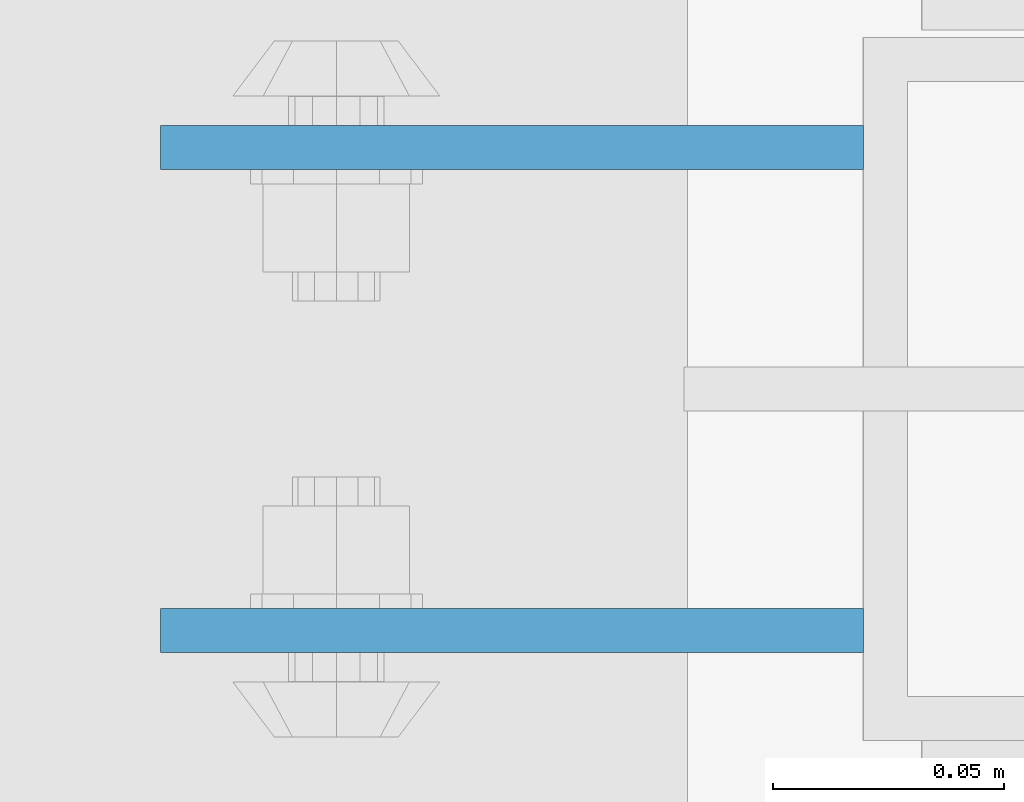
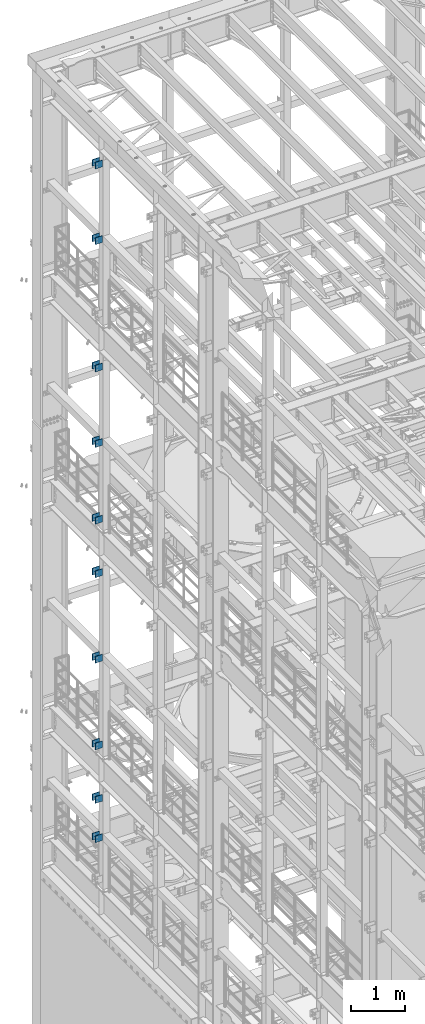
# One storey, part 1308 of 1876: 20 beams, 4 elements without a shape of their own.
"""IFC2X3 building model written with IfcOpenShell, lengths in millimetres."""

from ifc_helpers import new_model, si_unit, frame, origin_with_axes, place, context, subcontext, project, spatial, faceted_brep, material, type_object, element, aggregate, save


model = new_model("IFC2X3")

# Units and contexts
model_context = context("Model", 3, precision=1e-05, world=origin_with_axes())
body_context = subcontext(model_context, "Body", "Model", "MODEL_VIEW")
ifc_project = project(units=[si_unit("LENGTHUNIT", "METRE", prefix="MILLI"), si_unit("AREAUNIT", "SQUARE_METRE"), si_unit("VOLUMEUNIT", "CUBIC_METRE"), si_unit("MASSUNIT", "GRAM", prefix="KILO"), si_unit("TIMEUNIT", "SECOND"), si_unit("PLANEANGLEUNIT", "RADIAN"), si_unit("SOLIDANGLEUNIT", "STERADIAN"), si_unit("THERMODYNAMICTEMPERATUREUNIT", "DEGREE_CELSIUS"), si_unit("LUMINOUSINTENSITYUNIT", "LUMEN")], contexts=[model_context])

# Site, building, storey
site_placement = place(None, origin_with_axes())
site = spatial("IfcSite", under=ifc_project, at=site_placement, CompositionType="ELEMENT")
building_placement = place(site_placement, origin_with_axes())
building = spatial("IfcBuilding", under=site, at=building_placement, Name="Undefined", CompositionType="ELEMENT")
storey_placement = place(building_placement, origin_with_axes())
storey = spatial("IfcBuildingStorey", under=building, at=storey_placement, Name="Undefined", CompositionType="ELEMENT", Elevation=0.0)

# Assembly, beams
assembly_1_placement = place(storey_placement, origin_with_axes())
assembly_1 = element("IfcElementAssembly", 1, at=assembly_1_placement, inside=storey, Name="BEAM", AssemblyPlace="NOTDEFINED", PredefinedType="RIGID_FRAME")
ifc_material = material(Name="STEEL/A36")
beam_type = type_object("IfcBeamType", PredefinedType="NOTDEFINED")
beam_1_placement = place(assembly_1_placement, frame((-76.2000002548895, 11736.3875, 21678.9), z_axis=(0.0, 0.0, -1.0), x_axis=(-1.0, 0.0, 0.0)))
beam_1 = element("IfcBeam", 2, at=beam_1_placement, type_object=beam_type, material=ifc_material, Name="PLATE", context=body_context, shape_type="Brep", body=[
    faceted_brep([(0.0, 4.76249999999982, -76.1999999999998), (3.63797880709171e-12, 4.76249999999982, 76.1999969482422), (152.399993896484, 4.76250000000073, 76.1999969482422), (152.4, 4.76249999999982, -76.1999999999998), (3.63797880709171e-12, -4.76249999999982, 76.1999969482422), (152.399993896484, -4.76250000000073, 76.1999969482422), (0.0, -4.76249999999982, -76.1999999999998), (152.4, -4.76249999999982, -76.1999999999998)], [[[0, 1, 2, 3]], [[4, 5, 2, 1]], [[4, 6, 7, 5]], [[6, 0, 3, 7]], [[5, 7, 3, 2]], [[6, 4, 1, 0]]]),
])
beam_2_placement = place(assembly_1_placement, frame((-76.2000002548895, 11631.6125, 21678.9), z_axis=(0.0, 0.0, -1.0), x_axis=(-1.0, 0.0, 0.0)))
beam_2 = element("IfcBeam", 3, at=beam_2_placement, type_object=beam_type, material=ifc_material, Name="PLATE", context=body_context, shape_type="Brep", body=[
    faceted_brep([(0.0, 4.76249999999982, -76.1999999999998), (3.63797880709171e-12, 4.76249999999982, 76.1999969482422), (152.399993896484, 4.76250000000073, 76.1999969482422), (152.4, 4.76249999999982, -76.1999999999998), (3.63797880709171e-12, -4.76249999999982, 76.1999969482422), (152.399993896484, -4.76250000000073, 76.1999969482422), (0.0, -4.76249999999982, -76.1999999999998), (152.4, -4.76249999999982, -76.1999999999998)], [[[0, 1, 2, 3]], [[4, 5, 2, 1]], [[4, 6, 7, 5]], [[6, 0, 3, 7]], [[5, 7, 3, 2]], [[6, 4, 1, 0]]]),
])
beam_3_placement = place(assembly_1_placement, frame((-76.2000002548895, 11736.3875, 19958.05), z_axis=(0.0, 0.0, -1.0), x_axis=(-1.0, 0.0, 0.0)))
beam_3 = element("IfcBeam", 4, at=beam_3_placement, type_object=beam_type, material=ifc_material, Name="PLATE", context=body_context, shape_type="Brep", body=[
    faceted_brep([(0.0, 4.76249999999982, -76.1999999999998), (3.63797880709171e-12, 4.76249999999982, 76.1999969482422), (152.399993896484, 4.76250000000073, 76.1999969482422), (152.4, 4.76249999999982, -76.1999999999998), (3.63797880709171e-12, -4.76249999999982, 76.1999969482422), (152.399993896484, -4.76250000000073, 76.1999969482422), (0.0, -4.76249999999982, -76.1999999999998), (152.4, -4.76249999999982, -76.1999999999998)], [[[0, 1, 2, 3]], [[4, 5, 2, 1]], [[4, 6, 7, 5]], [[6, 0, 3, 7]], [[5, 7, 3, 2]], [[6, 4, 1, 0]]]),
])
beam_4_placement = place(assembly_1_placement, frame((-76.2000002548895, 11631.6125, 19958.05), z_axis=(0.0, 0.0, -1.0), x_axis=(-1.0, 0.0, 0.0)))
beam_4 = element("IfcBeam", 5, at=beam_4_placement, type_object=beam_type, material=ifc_material, Name="PLATE", context=body_context, shape_type="Brep", body=[
    faceted_brep([(0.0, 4.76249999999982, -76.1999999999998), (3.63797880709171e-12, 4.76249999999982, 76.1999969482422), (152.399993896484, 4.76250000000073, 76.1999969482422), (152.4, 4.76249999999982, -76.1999999999998), (3.63797880709171e-12, -4.76249999999982, 76.1999969482422), (152.399993896484, -4.76250000000073, 76.1999969482422), (0.0, -4.76249999999982, -76.1999999999998), (152.4, -4.76249999999982, -76.1999999999998)], [[[0, 1, 2, 3]], [[4, 5, 2, 1]], [[4, 6, 7, 5]], [[6, 0, 3, 7]], [[5, 7, 3, 2]], [[6, 4, 1, 0]]]),
])
aggregate(assembly_1, [beam_1, beam_2, beam_3, beam_4])

assembly_2_placement = place(storey_placement, origin_with_axes())
assembly_2 = element("IfcElementAssembly", 6, at=assembly_2_placement, inside=storey, Name="BEAM", AssemblyPlace="NOTDEFINED", PredefinedType="RIGID_FRAME")
beam_5_placement = place(assembly_2_placement, frame((-76.1999999999999, 11736.3875, 13589.0), z_axis=(0.0, 0.0, -1.0), x_axis=(-1.0, 0.0, 0.0)))
beam_5 = element("IfcBeam", 7, at=beam_5_placement, type_object=beam_type, material=ifc_material, Name="PLATE", context=body_context, shape_type="Brep", body=[
    faceted_brep([(0.0, 4.76249999999982, -76.1999999999998), (3.63797880709171e-12, 4.76249999999982, 76.1999969482422), (152.399993896484, 4.76250000000073, 76.1999969482422), (152.4, 4.76249999999982, -76.1999999999998), (3.63797880709171e-12, -4.76249999999982, 76.1999969482422), (152.399993896484, -4.76250000000073, 76.1999969482422), (0.0, -4.76249999999982, -76.1999999999998), (152.4, -4.76249999999982, -76.1999999999998)], [[[0, 1, 2, 3]], [[4, 5, 2, 1]], [[4, 6, 7, 5]], [[6, 0, 3, 7]], [[5, 7, 3, 2]], [[6, 4, 1, 0]]]),
])
beam_6_placement = place(assembly_2_placement, frame((-76.1999999999999, 11631.6125, 13589.0), z_axis=(0.0, 0.0, -1.0), x_axis=(-1.0, 0.0, 0.0)))
beam_6 = element("IfcBeam", 8, at=beam_6_placement, type_object=beam_type, material=ifc_material, Name="PLATE", context=body_context, shape_type="Brep", body=[
    faceted_brep([(0.0, 4.76249999999982, -76.1999999999998), (3.63797880709171e-12, 4.76249999999982, 76.1999969482422), (152.399993896484, 4.76250000000073, 76.1999969482422), (152.4, 4.76249999999982, -76.1999999999998), (3.63797880709171e-12, -4.76249999999982, 76.1999969482422), (152.399993896484, -4.76250000000073, 76.1999969482422), (0.0, -4.76249999999982, -76.1999999999998), (152.4, -4.76249999999982, -76.1999999999998)], [[[0, 1, 2, 3]], [[4, 5, 2, 1]], [[4, 6, 7, 5]], [[6, 0, 3, 7]], [[5, 7, 3, 2]], [[6, 4, 1, 0]]]),
])
beam_7_placement = place(assembly_2_placement, frame((-76.2, 11736.3875, 17056.1), z_axis=(0.0, 0.0, -1.0), x_axis=(-1.0, 0.0, 0.0)))
beam_7 = element("IfcBeam", 9, at=beam_7_placement, type_object=beam_type, material=ifc_material, Name="PLATE", context=body_context, shape_type="Brep", body=[
    faceted_brep([(0.0, 4.76249999999982, -76.1999999999998), (3.63797880709171e-12, 4.76249999999982, 76.1999969482422), (152.399993896484, 4.76250000000073, 76.1999969482422), (152.4, 4.76249999999982, -76.1999999999998), (3.63797880709171e-12, -4.76249999999982, 76.1999969482422), (152.399993896484, -4.76250000000073, 76.1999969482422), (0.0, -4.76249999999982, -76.1999999999998), (152.4, -4.76249999999982, -76.1999999999998)], [[[0, 1, 2, 3]], [[4, 5, 2, 1]], [[4, 6, 7, 5]], [[6, 0, 3, 7]], [[5, 7, 3, 2]], [[6, 4, 1, 0]]]),
])
beam_8_placement = place(assembly_2_placement, frame((-76.2, 11631.6125, 17056.1), z_axis=(0.0, 0.0, -1.0), x_axis=(-1.0, 0.0, 0.0)))
beam_8 = element("IfcBeam", 10, at=beam_8_placement, type_object=beam_type, material=ifc_material, Name="PLATE", context=body_context, shape_type="Brep", body=[
    faceted_brep([(0.0, 4.76249999999982, -76.1999999999998), (3.63797880709171e-12, 4.76249999999982, 76.1999969482422), (152.399993896484, 4.76250000000073, 76.1999969482422), (152.4, 4.76249999999982, -76.1999999999998), (3.63797880709171e-12, -4.76249999999982, 76.1999969482422), (152.399993896484, -4.76250000000073, 76.1999969482422), (0.0, -4.76249999999982, -76.1999999999998), (152.4, -4.76249999999982, -76.1999999999998)], [[[0, 1, 2, 3]], [[4, 5, 2, 1]], [[4, 6, 7, 5]], [[6, 0, 3, 7]], [[5, 7, 3, 2]], [[6, 4, 1, 0]]]),
])
beam_9_placement = place(assembly_2_placement, frame((-76.2, 11736.3875, 15335.25), z_axis=(0.0, 0.0, -1.0), x_axis=(-1.0, 0.0, 0.0)))
beam_9 = element("IfcBeam", 11, at=beam_9_placement, type_object=beam_type, material=ifc_material, Name="PLATE", context=body_context, shape_type="Brep", body=[
    faceted_brep([(0.0, 4.76249999999982, -76.1999999999998), (3.63797880709171e-12, 4.76249999999982, 76.1999969482422), (152.399993896484, 4.76250000000073, 76.1999969482422), (152.4, 4.76249999999982, -76.1999999999998), (3.63797880709171e-12, -4.76249999999982, 76.1999969482422), (152.399993896484, -4.76250000000073, 76.1999969482422), (0.0, -4.76249999999982, -76.1999999999998), (152.4, -4.76249999999982, -76.1999999999998)], [[[0, 1, 2, 3]], [[4, 5, 2, 1]], [[4, 6, 7, 5]], [[6, 0, 3, 7]], [[5, 7, 3, 2]], [[6, 4, 1, 0]]]),
])
beam_10_placement = place(assembly_2_placement, frame((-76.2, 11631.6125, 15335.25), z_axis=(0.0, 0.0, -1.0), x_axis=(-1.0, 0.0, 0.0)))
beam_10 = element("IfcBeam", 12, at=beam_10_placement, type_object=beam_type, material=ifc_material, Name="PLATE", context=body_context, shape_type="Brep", body=[
    faceted_brep([(0.0, 4.76249999999982, -76.1999999999998), (3.63797880709171e-12, 4.76249999999982, 76.1999969482422), (152.399993896484, 4.76250000000073, 76.1999969482422), (152.4, 4.76249999999982, -76.1999999999998), (3.63797880709171e-12, -4.76249999999982, 76.1999969482422), (152.399993896484, -4.76250000000073, 76.1999969482422), (0.0, -4.76249999999982, -76.1999999999998), (152.4, -4.76249999999982, -76.1999999999998)], [[[0, 1, 2, 3]], [[4, 5, 2, 1]], [[4, 6, 7, 5]], [[6, 0, 3, 7]], [[5, 7, 3, 2]], [[6, 4, 1, 0]]]),
])
aggregate(assembly_2, [beam_5, beam_6, beam_7, beam_8, beam_9, beam_10])

assembly_3_placement = place(storey_placement, origin_with_axes())
assembly_3 = element("IfcElementAssembly", 13, at=assembly_3_placement, inside=storey, Name="BEAM", AssemblyPlace="NOTDEFINED", PredefinedType="RIGID_FRAME")
beam_11_placement = place(assembly_3_placement, frame((-76.1999999999999, 11736.3875, 12369.8), z_axis=(0.0, 0.0, -1.0), x_axis=(-1.0, 0.0, 0.0)))
beam_11 = element("IfcBeam", 14, at=beam_11_placement, type_object=beam_type, material=ifc_material, Name="PLATE", context=body_context, shape_type="Brep", body=[
    faceted_brep([(0.0, 4.76249999999982, -76.1999999999998), (3.63797880709171e-12, 4.76249999999982, 76.1999969482422), (152.399993896484, 4.76250000000073, 76.1999969482422), (152.4, 4.76249999999982, -76.1999999999998), (3.63797880709171e-12, -4.76249999999982, 76.1999969482422), (152.399993896484, -4.76250000000073, 76.1999969482422), (0.0, -4.76249999999982, -76.1999999999998), (152.4, -4.76249999999982, -76.1999999999998)], [[[0, 1, 2, 3]], [[4, 5, 2, 1]], [[4, 6, 7, 5]], [[6, 0, 3, 7]], [[5, 7, 3, 2]], [[6, 4, 1, 0]]]),
])
beam_12_placement = place(assembly_3_placement, frame((-76.1999999999999, 11631.6125, 12369.8), z_axis=(0.0, 0.0, -1.0), x_axis=(-1.0, 0.0, 0.0)))
beam_12 = element("IfcBeam", 15, at=beam_12_placement, type_object=beam_type, material=ifc_material, Name="PLATE", context=body_context, shape_type="Brep", body=[
    faceted_brep([(0.0, 4.76249999999982, -76.1999999999998), (3.63797880709171e-12, 4.76249999999982, 76.1999969482422), (152.399993896484, 4.76250000000073, 76.1999969482422), (152.4, 4.76249999999982, -76.1999999999998), (3.63797880709171e-12, -4.76249999999982, 76.1999969482422), (152.399993896484, -4.76250000000073, 76.1999969482422), (0.0, -4.76249999999982, -76.1999999999998), (152.4, -4.76249999999982, -76.1999999999998)], [[[0, 1, 2, 3]], [[4, 5, 2, 1]], [[4, 6, 7, 5]], [[6, 0, 3, 7]], [[5, 7, 3, 2]], [[6, 4, 1, 0]]]),
])
beam_13_placement = place(assembly_3_placement, frame((-76.2, 11736.3875, 8445.5), z_axis=(0.0, 0.0, -1.0), x_axis=(-1.0, 0.0, 0.0)))
beam_13 = element("IfcBeam", 16, at=beam_13_placement, type_object=beam_type, material=ifc_material, Name="PLATE", context=body_context, shape_type="Brep", body=[
    faceted_brep([(0.0, 4.76249999999982, -76.1999999999998), (3.63797880709171e-12, 4.76249999999982, 76.1999969482422), (152.399993896484, 4.76250000000073, 76.1999969482422), (152.4, 4.76249999999982, -76.1999999999998), (3.63797880709171e-12, -4.76249999999982, 76.1999969482422), (152.399993896484, -4.76250000000073, 76.1999969482422), (0.0, -4.76249999999982, -76.1999999999998), (152.4, -4.76249999999982, -76.1999999999998)], [[[0, 1, 2, 3]], [[4, 5, 2, 1]], [[4, 6, 7, 5]], [[6, 0, 3, 7]], [[5, 7, 3, 2]], [[6, 4, 1, 0]]]),
])
beam_14_placement = place(assembly_3_placement, frame((-76.2, 11631.6125, 8445.5), z_axis=(0.0, 0.0, -1.0), x_axis=(-1.0, 0.0, 0.0)))
beam_14 = element("IfcBeam", 17, at=beam_14_placement, type_object=beam_type, material=ifc_material, Name="PLATE", context=body_context, shape_type="Brep", body=[
    faceted_brep([(0.0, 4.76249999999982, -76.1999999999998), (3.63797880709171e-12, 4.76249999999982, 76.1999969482422), (152.399993896484, 4.76250000000073, 76.1999969482422), (152.4, 4.76249999999982, -76.1999999999998), (3.63797880709171e-12, -4.76249999999982, 76.1999969482422), (152.399993896484, -4.76250000000073, 76.1999969482422), (0.0, -4.76249999999982, -76.1999999999998), (152.4, -4.76249999999982, -76.1999999999998)], [[[0, 1, 2, 3]], [[4, 5, 2, 1]], [[4, 6, 7, 5]], [[6, 0, 3, 7]], [[5, 7, 3, 2]], [[6, 4, 1, 0]]]),
])
beam_15_placement = place(assembly_3_placement, frame((-76.2, 11736.3875, 10420.35), z_axis=(0.0, 0.0, -1.0), x_axis=(-1.0, 0.0, 0.0)))
beam_15 = element("IfcBeam", 18, at=beam_15_placement, type_object=beam_type, material=ifc_material, Name="PLATE", context=body_context, shape_type="Brep", body=[
    faceted_brep([(0.0, 4.76249999999982, -76.1999999999998), (3.63797880709171e-12, 4.76249999999982, 76.1999969482422), (152.399993896484, 4.76250000000073, 76.1999969482422), (152.4, 4.76249999999982, -76.1999999999998), (3.63797880709171e-12, -4.76249999999982, 76.1999969482422), (152.399993896484, -4.76250000000073, 76.1999969482422), (0.0, -4.76249999999982, -76.1999999999998), (152.4, -4.76249999999982, -76.1999999999998)], [[[0, 1, 2, 3]], [[4, 5, 2, 1]], [[4, 6, 7, 5]], [[6, 0, 3, 7]], [[5, 7, 3, 2]], [[6, 4, 1, 0]]]),
])
beam_16_placement = place(assembly_3_placement, frame((-76.2, 11631.6125, 10420.35), z_axis=(0.0, 0.0, -1.0), x_axis=(-1.0, 0.0, 0.0)))
beam_16 = element("IfcBeam", 19, at=beam_16_placement, type_object=beam_type, material=ifc_material, Name="PLATE", context=body_context, shape_type="Brep", body=[
    faceted_brep([(0.0, 4.76249999999982, -76.1999999999998), (3.63797880709171e-12, 4.76249999999982, 76.1999969482422), (152.399993896484, 4.76250000000073, 76.1999969482422), (152.4, 4.76249999999982, -76.1999999999998), (3.63797880709171e-12, -4.76249999999982, 76.1999969482422), (152.399993896484, -4.76250000000073, 76.1999969482422), (0.0, -4.76249999999982, -76.1999999999998), (152.4, -4.76249999999982, -76.1999999999998)], [[[0, 1, 2, 3]], [[4, 5, 2, 1]], [[4, 6, 7, 5]], [[6, 0, 3, 7]], [[5, 7, 3, 2]], [[6, 4, 1, 0]]]),
])
aggregate(assembly_3, [beam_11, beam_12, beam_13, beam_14, beam_15, beam_16])

assembly_4_placement = place(storey_placement, origin_with_axes())
assembly_4 = element("IfcElementAssembly", 20, at=assembly_4_placement, inside=storey, Name="BEAM", AssemblyPlace="NOTDEFINED", PredefinedType="RIGID_FRAME")
beam_17_placement = place(assembly_4_placement, frame((-76.2, 11736.3875, 6330.95), z_axis=(0.0, 0.0, -1.0), x_axis=(-1.0, 0.0, 0.0)))
beam_17 = element("IfcBeam", 21, at=beam_17_placement, type_object=beam_type, material=ifc_material, Name="PLATE", context=body_context, shape_type="Brep", body=[
    faceted_brep([(0.0, 4.76249999999982, -76.1999999999998), (3.63797880709171e-12, 4.76249999999982, 76.1999969482422), (152.399993896484, 4.76250000000073, 76.1999969482422), (152.4, 4.76249999999982, -76.1999999999998), (3.63797880709171e-12, -4.76249999999982, 76.1999969482422), (152.399993896484, -4.76250000000073, 76.1999969482422), (0.0, -4.76249999999982, -76.1999999999998), (152.4, -4.76249999999982, -76.1999999999998)], [[[0, 1, 2, 3]], [[4, 5, 2, 1]], [[4, 6, 7, 5]], [[6, 0, 3, 7]], [[5, 7, 3, 2]], [[6, 4, 1, 0]]]),
])
beam_18_placement = place(assembly_4_placement, frame((-76.2, 11631.6125, 6330.95), z_axis=(0.0, 0.0, -1.0), x_axis=(-1.0, 0.0, 0.0)))
beam_18 = element("IfcBeam", 22, at=beam_18_placement, type_object=beam_type, material=ifc_material, Name="PLATE", context=body_context, shape_type="Brep", body=[
    faceted_brep([(0.0, 4.76249999999982, -76.1999999999998), (3.63797880709171e-12, 4.76249999999982, 76.1999969482422), (152.399993896484, 4.76250000000073, 76.1999969482422), (152.4, 4.76249999999982, -76.1999999999998), (3.63797880709171e-12, -4.76249999999982, 76.1999969482422), (152.399993896484, -4.76250000000073, 76.1999969482422), (0.0, -4.76249999999982, -76.1999999999998), (152.4, -4.76249999999982, -76.1999999999998)], [[[0, 1, 2, 3]], [[4, 5, 2, 1]], [[4, 6, 7, 5]], [[6, 0, 3, 7]], [[5, 7, 3, 2]], [[6, 4, 1, 0]]]),
])
beam_19_placement = place(assembly_4_placement, frame((-76.2, 11736.3875, 7226.3), z_axis=(0.0, 0.0, -1.0), x_axis=(-1.0, 0.0, 0.0)))
beam_19 = element("IfcBeam", 23, at=beam_19_placement, type_object=beam_type, material=ifc_material, Name="PLATE", context=body_context, shape_type="Brep", body=[
    faceted_brep([(0.0, 4.76249999999982, -76.1999999999998), (3.63797880709171e-12, 4.76249999999982, 76.1999969482422), (152.399993896484, 4.76250000000073, 76.1999969482422), (152.4, 4.76249999999982, -76.1999999999998), (3.63797880709171e-12, -4.76249999999982, 76.1999969482422), (152.399993896484, -4.76250000000073, 76.1999969482422), (0.0, -4.76249999999982, -76.1999999999998), (152.4, -4.76249999999982, -76.1999999999998)], [[[0, 1, 2, 3]], [[4, 5, 2, 1]], [[4, 6, 7, 5]], [[6, 0, 3, 7]], [[5, 7, 3, 2]], [[6, 4, 1, 0]]]),
])
beam_20_placement = place(assembly_4_placement, frame((-76.2, 11631.6125, 7226.3), z_axis=(0.0, 0.0, -1.0), x_axis=(-1.0, 0.0, 0.0)))
beam_20 = element("IfcBeam", 24, at=beam_20_placement, type_object=beam_type, material=ifc_material, Name="PLATE", context=body_context, shape_type="Brep", body=[
    faceted_brep([(0.0, 4.76249999999982, -76.1999999999998), (3.63797880709171e-12, 4.76249999999982, 76.1999969482422), (152.399993896484, 4.76250000000073, 76.1999969482422), (152.4, 4.76249999999982, -76.1999999999998), (3.63797880709171e-12, -4.76249999999982, 76.1999969482422), (152.399993896484, -4.76250000000073, 76.1999969482422), (0.0, -4.76249999999982, -76.1999999999998), (152.4, -4.76249999999982, -76.1999999999998)], [[[0, 1, 2, 3]], [[4, 5, 2, 1]], [[4, 6, 7, 5]], [[6, 0, 3, 7]], [[5, 7, 3, 2]], [[6, 4, 1, 0]]]),
])
aggregate(assembly_4, [beam_17, beam_18, beam_19, beam_20])

save(model, "model.ifc")
